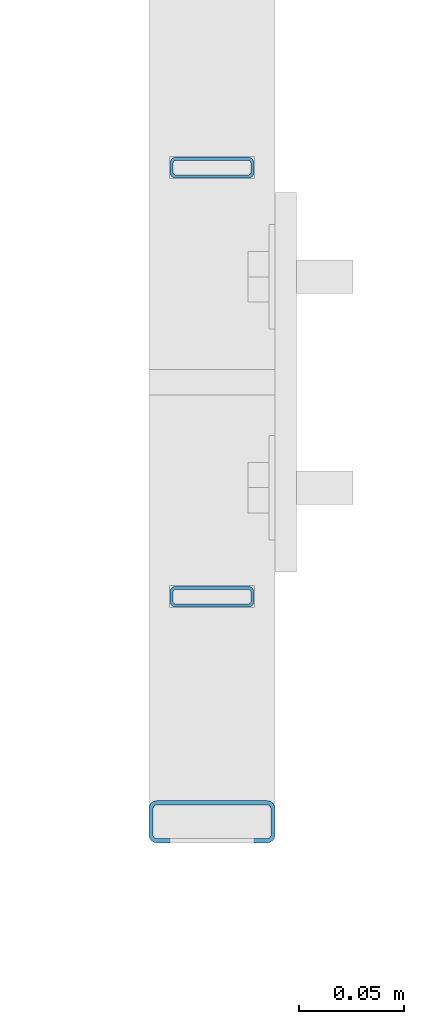
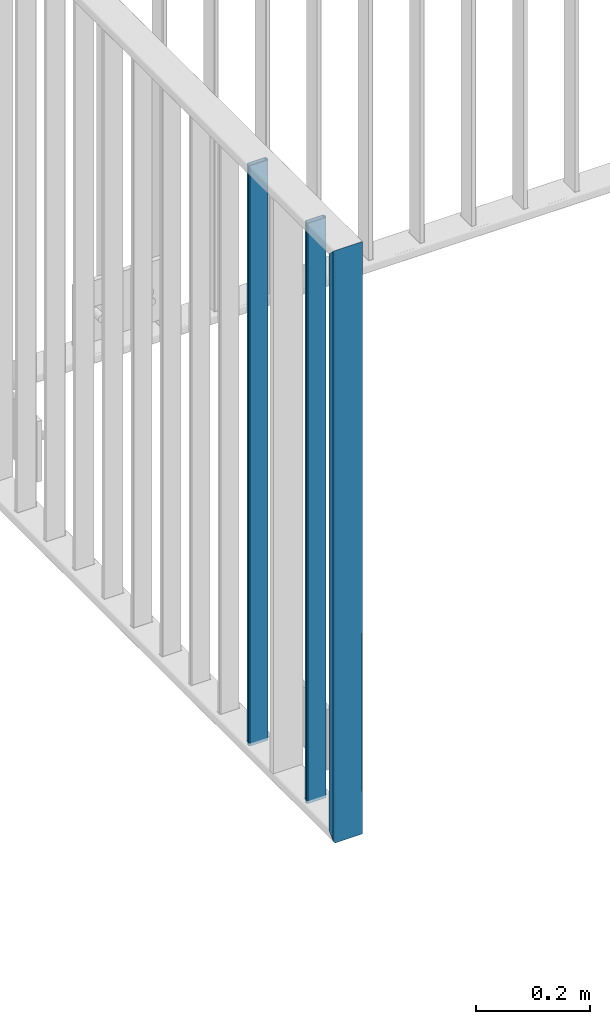
# One storey, part 23 of 156: 3 beams, 1 element without a shape of its own.
"""IFC2X3 building model written with IfcOpenShell, lengths in millimetres."""

from ifc_helpers import new_model, si_unit, frame, origin_with_axes, origin_2d_with_axis, place, context, subcontext, project, spatial, hollow_rectangle, extrude, clip, halfspace, material, type_object, element, aggregate, save


model = new_model("IFC2X3")

# Units and contexts
model_context = context("Model", 3, precision=1e-05, world=origin_with_axes())
body_context = subcontext(model_context, "Body", "Model", "MODEL_VIEW")
ifc_project = project(units=[si_unit("LENGTHUNIT", "METRE", prefix="MILLI"), si_unit("AREAUNIT", "SQUARE_METRE"), si_unit("VOLUMEUNIT", "CUBIC_METRE"), si_unit("MASSUNIT", "GRAM", prefix="KILO"), si_unit("TIMEUNIT", "SECOND"), si_unit("PLANEANGLEUNIT", "RADIAN"), si_unit("SOLIDANGLEUNIT", "STERADIAN"), si_unit("THERMODYNAMICTEMPERATUREUNIT", "DEGREE_CELSIUS"), si_unit("LUMINOUSINTENSITYUNIT", "LUMEN")], contexts=[model_context])

# Site, building, storey
site_placement = place(None, origin_with_axes())
site = spatial("IfcSite", under=ifc_project, at=site_placement, CompositionType="ELEMENT")
building_placement = place(site_placement, origin_with_axes())
building = spatial("IfcBuilding", under=site, at=building_placement, Name="Undefined", CompositionType="ELEMENT")
storey_placement = place(building_placement, origin_with_axes())
storey = spatial("IfcBuildingStorey", under=building, at=storey_placement, Name="Undefined", CompositionType="ELEMENT", Elevation=0.0)

# Assembly, beams
assembly_placement = place(storey_placement, origin_with_axes())
assembly = element("IfcElementAssembly", 1, at=assembly_placement, inside=storey, AssemblyPlace="NOTDEFINED", PredefinedType="RIGID_FRAME")
ifc_material = material(Name="STEEL/S235JR")
beam_type_1 = type_object("IfcBeamType", Name="K60/20/2", PredefinedType="NOTDEFINED")
beam_1_placement = place(assembly_placement, frame((31475.0005187988, 20158.0016473224, 4000.0), z_axis=(1.0, 0.0, 0.0), x_axis=(0.0, 0.0, -1.0)))
beam_1 = element("IfcBeam", 2, at=beam_1_placement, type_object=beam_type_1, material=ifc_material, ObjectType="K60/20/2", context=body_context, shape_type="Clipping", body=[
    clip(clip(extrude(hollow_rectangle(XDim=20.0, YDim=60.0, WallThickness=2.0, InnerFilletRadius=2.0, OuterFilletRadius=4.0, at=origin_2d_with_axis()), frame((1280.2, 0.0, 0.0), z_axis=(-1.0, 0.0, 0.0), x_axis=(0.0, -1.0, 0.0)), (0.0, 0.0, 1.0), 1290.4), halfspace(frame((1270.0, -10.0, 0.0), z_axis=(0.707106781186548, 0.707106781186548, 0.0), x_axis=(0.0, 0.0, 1.0)), False)), halfspace(frame((20.0, 10.0, 0.0), z_axis=(-0.707106781186548, 0.707106781186548, 0.0), x_axis=(0.0, 0.0, 1.0)), False)),
])
beam_type_2 = type_object("IfcBeamType", Name="K40/10/1.5", PredefinedType="NOTDEFINED")
beam_2_placement = place(assembly_placement, frame((31474.9983597497, 20264.8507649865, 3980.00000000003), z_axis=(1.0, 0.0, 0.0), x_axis=(0.0, 0.0, -1.0)))
beam_2 = element("IfcBeam", 3, at=beam_2_placement, type_object=beam_type_2, material=ifc_material, ObjectType="K40/10/1.5", context=body_context, shape_type="Clipping", body=[
    clip(clip(extrude(hollow_rectangle(XDim=10.0, YDim=40.0, WallThickness=1.5, InnerFilletRadius=1.5, OuterFilletRadius=3.0, at=origin_2d_with_axis()), frame((1237.00000000003, 0.0, 0.0), z_axis=(-1.0, 0.0, 0.0), x_axis=(0.0, -1.0, 0.0)), (0.0, 0.0, 1.0), 1244.0), halfspace(frame((1237.00000000003, 3.63803898150218, 46.7940496082883), z_axis=(1.0, 0.0, 0.0), x_axis=(0.0, -0.758923924280425, -0.65117929724063)), False)), halfspace(frame((-6.99999999997453, -3.63803898149854, 46.7940496082956), z_axis=(-1.0, 0.0, 0.0), x_axis=(0.0, 0.75892392428044, -0.651179297240612)), False)),
])
beam_3_placement = place(assembly_placement, frame((31474.9983597497, 20468.4107649865, 3980.00000000003), z_axis=(1.0, 0.0, 0.0), x_axis=(0.0, 0.0, -1.0)))
beam_3 = element("IfcBeam", 4, at=beam_3_placement, type_object=beam_type_2, material=ifc_material, ObjectType="K40/10/1.5", context=body_context, shape_type="Clipping", body=[
    clip(clip(extrude(hollow_rectangle(XDim=10.0, YDim=40.0, WallThickness=1.5, InnerFilletRadius=1.5, OuterFilletRadius=3.0, at=origin_2d_with_axis()), frame((1237.00000000003, 0.0, 0.0), z_axis=(-1.0, 0.0, 0.0), x_axis=(0.0, -1.0, 0.0)), (0.0, 0.0, 1.0), 1244.0), halfspace(frame((1237.00000000003, 3.63803898150218, 46.7940496082883), z_axis=(1.0, 0.0, 0.0), x_axis=(0.0, -0.758923924280425, -0.65117929724063)), False)), halfspace(frame((-6.99999999997453, -3.63803898149854, 46.7940496082956), z_axis=(-1.0, 0.0, 0.0), x_axis=(0.0, 0.75892392428044, -0.651179297240612)), False)),
])
aggregate(assembly, [beam_2, beam_3, beam_1])

save(model, "model.ifc")
